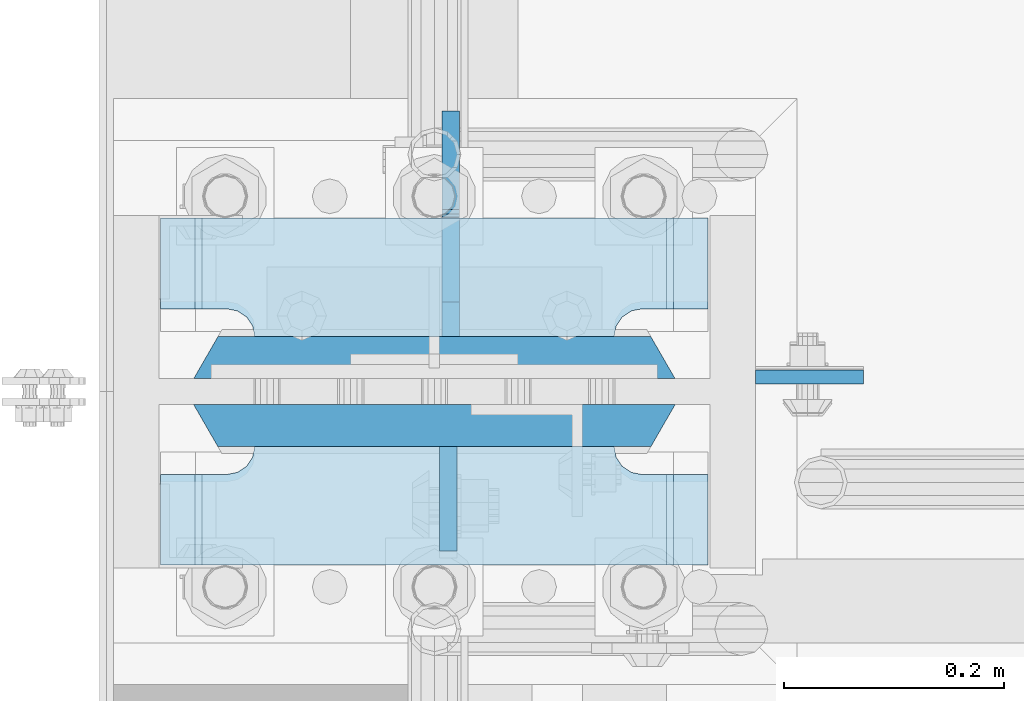
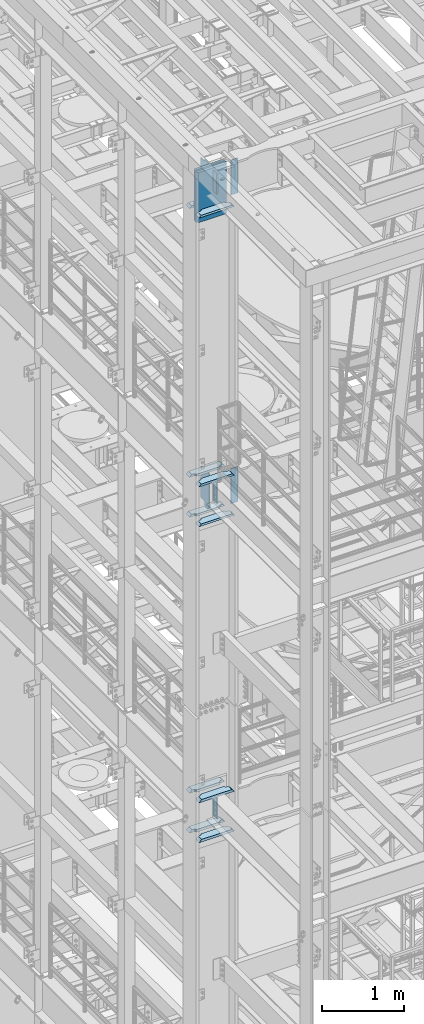
# One storey, part 1463 of 1876: 19 plates, 2 elements without a shape of their own.
"""IFC2X3 building model written with IfcOpenShell, lengths in millimetres."""

from ifc_helpers import new_model, si_unit, frame, origin_with_axes, place, context, subcontext, project, spatial, faceted_brep, material, type_object, element, aggregate, save


model = new_model("IFC2X3")

# Units and contexts
model_context = context("Model", 3, precision=1e-05, world=origin_with_axes())
body_context = subcontext(model_context, "Body", "Model", "MODEL_VIEW")
ifc_project = project(units=[si_unit("LENGTHUNIT", "METRE", prefix="MILLI"), si_unit("AREAUNIT", "SQUARE_METRE"), si_unit("VOLUMEUNIT", "CUBIC_METRE"), si_unit("MASSUNIT", "GRAM", prefix="KILO"), si_unit("TIMEUNIT", "SECOND"), si_unit("PLANEANGLEUNIT", "RADIAN"), si_unit("SOLIDANGLEUNIT", "STERADIAN"), si_unit("THERMODYNAMICTEMPERATUREUNIT", "DEGREE_CELSIUS"), si_unit("LUMINOUSINTENSITYUNIT", "LUMEN")], contexts=[model_context])

# Site, building, storey
site_placement = place(None, origin_with_axes())
site = spatial("IfcSite", under=ifc_project, at=site_placement, CompositionType="ELEMENT")
building_placement = place(site_placement, origin_with_axes())
building = spatial("IfcBuilding", under=site, at=building_placement, Name="Undefined", CompositionType="ELEMENT")
storey_placement = place(building_placement, origin_with_axes())
storey = spatial("IfcBuildingStorey", under=building, at=storey_placement, Name="Undefined", CompositionType="ELEMENT", Elevation=0.0)

# Assembly, plates
assembly_1_placement = place(storey_placement, origin_with_axes())
assembly_1 = element("IfcElementAssembly", 1, at=assembly_1_placement, inside=storey, Name="COLUMN", AssemblyPlace="NOTDEFINED", PredefinedType="RIGID_FRAME")
ifc_material_1 = material(Name="STEEL/A572-50")
plate_type_1 = type_object("IfcPlateType", PredefinedType="NOTDEFINED")
plate_1_placement = place(assembly_1_placement, frame((292.1, -4558.50699987411, 17929.225), z_axis=(1.0, 0.0, 0.0), x_axis=(0.0, 0.0, -1.0)))
plate_1 = element("IfcPlate", 2, at=plate_1_placement, type_object=plate_type_1, material=ifc_material_1, Name="PLATE", context=body_context, shape_type="Brep", body=[
    faceted_brep([(0.0, -6.35000000000036, 0.0), (0.0, -6.34999999999991, 98.4250030517578), (0.0, 6.34999999999991, 98.4250030517578), (0.0, 6.35000000000036, 0.0), (514.349975585938, -6.35000000000036, 98.4250030517578), (514.349975585938, 6.35000000000036, 98.4250030517578), (514.349975585938, -6.35000000000036, 0.0), (514.349975585938, 6.35000000000036, 0.0)], [[[0, 1, 2, 3]], [[1, 4, 5, 2]], [[4, 6, 7, 5]], [[6, 0, 3, 7]], [[5, 7, 3, 2]], [[6, 4, 1, 0]]]),
])
plate_2_placement = place(assembly_1_placement, frame((292.1, -4558.50699987411, 22501.225), z_axis=(1.0, 0.0, 0.0), x_axis=(0.0, 0.0, -1.0)))
plate_2 = element("IfcPlate", 3, at=plate_2_placement, type_object=plate_type_1, material=ifc_material_1, Name="PLATE", context=body_context, shape_type="Brep", body=[
    faceted_brep([(0.0, -6.35000000000036, 0.0), (0.0, -6.34999999999991, 98.4250030517578), (0.0, 6.34999999999991, 98.4250030517578), (0.0, 6.35000000000036, 0.0), (514.349975585938, -6.35000000000036, 98.4250030517578), (514.349975585938, 6.35000000000036, 98.4250030517578), (514.349975585938, -6.35000000000036, 0.0), (514.349975585938, 6.35000000000036, 0.0)], [[[0, 1, 2, 3]], [[1, 4, 5, 2]], [[4, 6, 7, 5]], [[6, 0, 3, 7]], [[5, 7, 3, 2]], [[6, 4, 1, 0]]]),
])
ifc_material_2 = material(Name="STEEL/A572-GR.50")
plate_type_2 = type_object("IfcPlateType", PredefinedType="NOTDEFINED")
plate_3_placement = place(assembly_1_placement, frame((-219.075, -4541.04375, 22523.45), z_axis=(1.0, 0.0, 0.0), x_axis=(0.0, 0.0, -1.0)))
plate_3 = element("IfcPlate", 4, at=plate_3_placement, type_object=plate_type_2, material=ifc_material_2, Name="PLATE", context=body_context, shape_type="Brep", body=[
    faceted_brep([(0.0, 19.0500000000002, 416.152954742277), (0.0, -19.0500000000002, 438.149993896484), (742.950012207031, -19.0500000000002, 438.149993896484), (742.950012207031, 19.0500000000002, 416.152954742277), (742.950012207031, 19.0500000000002, 21.9970452577325), (0.0, 19.0500000000002, 21.9970452577367), (0.0, -19.0500000000002, 0.0), (742.950012207031, -19.0500000000002, 0.0)], [[[0, 1, 2, 3]], [[0, 3, 4, 5]], [[1, 0, 5, 6]], [[2, 1, 6, 7]], [[3, 2, 7, 4]], [[6, 5, 4, 7]]]),
])
plate_4_placement = place(assembly_1_placement, frame((-219.075, -4602.95625, 22523.45), z_axis=(1.0, 0.0, 0.0), x_axis=(0.0, 0.0, -1.0)))
plate_4 = element("IfcPlate", 5, at=plate_4_placement, type_object=plate_type_2, material=ifc_material_2, Name="PLATE", context=body_context, shape_type="Brep", body=[
    faceted_brep([(0.0, -19.0500000000002, 416.152954749452), (742.950012207031, -19.0500000000002, 416.152954749372), (742.950012207031, 19.0500000000002, 438.149993896484), (0.0, 19.0500000000002, 438.149993896484), (742.950012207031, -19.0500000000002, 21.9970452506512), (742.950012207031, 19.0500000000002, 0.0), (-9.09494701772928e-13, 19.05, -1.81898940354586e-12), (0.0, -19.0500000000002, 21.9970452506512)], [[[0, 1, 2, 3]], [[2, 1, 4, 5]], [[3, 2, 5, 6]], [[0, 3, 6, 7]], [[1, 0, 7, 4]], [[6, 5, 4, 7]]]),
])
plate_type_3 = type_object("IfcPlateType", PredefinedType="NOTDEFINED")
plate_5_placement = place(assembly_1_placement, frame((12.6995000839233, -4622.00625, 22491.7), z_axis=(0.0, -1.0, 0.0), x_axis=(0.0, 0.0, -1.0)))
plate_5 = element("IfcPlate", 6, at=plate_5_placement, type_object=plate_type_3, material=ifc_material_1, Name="PLATE", context=body_context, shape_type="Brep", body=[
    faceted_brep([(0.0, -7.9375, 0.0), (0.0, -7.9375, 95.25), (0.0, 7.9375, 95.25), (0.0, 7.9375, 0.0), (304.799987792969, -7.9375, 95.25), (304.799987792969, 7.9375, 95.25), (304.799987792969, -7.9375, 0.0), (304.799987792969, 7.9375, 0.0)], [[[0, 1, 2, 3]], [[1, 4, 5, 2]], [[4, 6, 7, 5]], [[6, 0, 3, 7]], [[5, 7, 3, 2]], [[6, 4, 1, 0]]]),
])
plate_6_placement = place(assembly_1_placement, frame((12.6995000839233, -4622.00625, 17919.7), z_axis=(0.0, -1.0, 0.0), x_axis=(0.0, 0.0, -1.0)))
plate_6 = element("IfcPlate", 7, at=plate_6_placement, type_object=plate_type_3, material=ifc_material_1, Name="PLATE", context=body_context, shape_type="Brep", body=[
    faceted_brep([(0.0, -7.9375, 0.0), (0.0, -7.9375, 95.25), (0.0, 7.9375, 95.25), (0.0, 7.9375, 0.0), (304.799987792969, -7.9375, 95.25), (304.799987792969, 7.9375, 95.25), (304.799987792969, -7.9375, 0.0), (304.799987792969, 7.9375, 0.0)], [[[0, 1, 2, 3]], [[1, 4, 5, 2]], [[4, 6, 7, 5]], [[6, 0, 3, 7]], [[5, 7, 3, 2]], [[6, 4, 1, 0]]]),
])

# Assembly, plate
assembly_2_placement = place(storey_placement, origin_with_axes())
assembly_2 = element("IfcElementAssembly", 8, at=assembly_2_placement, inside=storey, Name="COLUMN", AssemblyPlace="NOTDEFINED", PredefinedType="RIGID_FRAME")
ifc_material_3 = material(Name="STEEL/A36")
plate_7_placement = place(assembly_2_placement, frame((12.6995000839233, -4622.00625, 13246.1), z_axis=(0.0, -1.0, 0.0), x_axis=(0.0, 0.0, -1.0)))
plate_7 = element("IfcPlate", 9, at=plate_7_placement, type_object=plate_type_3, material=ifc_material_3, Name="PLATE", context=body_context, shape_type="Brep", body=[
    faceted_brep([(0.0, -7.9375, 0.0), (0.0, -7.9375, 95.25), (0.0, 7.9375, 95.25), (0.0, 7.9375, 0.0), (304.799987792969, -7.9375, 95.25), (304.799987792969, 7.9375, 95.25), (304.799987792969, -7.9375, 0.0), (304.799987792969, 7.9375, 0.0)], [[[0, 1, 2, 3]], [[1, 4, 5, 2]], [[4, 6, 7, 5]], [[6, 0, 3, 7]], [[5, 7, 3, 2]], [[6, 4, 1, 0]]]),
])

# Plate
plate_type_4 = type_object("IfcPlateType", PredefinedType="NOTDEFINED")
plate_8_placement = place(assembly_1_placement, frame((249.2375, -4622.00625, 17376.775012207), z_axis=(-1.0, 0.0, 0.0), x_axis=(0.0, -1.0, 0.0)))
plate_8 = element("IfcPlate", 10, at=plate_8_placement, type_object=plate_type_4, material=ifc_material_1, Name="PLATE", context=body_context, shape_type="Brep", body=[
    faceted_brep([(107.949996948242, -15.875, 498.475006103516), (107.949996948242, 15.875, 467.025007631571), (25.3999996185303, 15.875, 467.025007631571), (25.3999996185303, -15.875, 498.475006103516), (23.4665397733534, -15.875, 428.429848211837), (25.3999996185303, -15.875, 438.150007247925), (25.3999996185303, 15.875, 438.150007247925), (23.4665397733534, 15.875, 428.429848211837), (17.9605119723965, -15.875, 420.189495275529), (17.9605119723965, 15.875, 420.189495275529), (9.72015903608917, -15.875, 414.683467474573), (9.72015903608917, 15.875, 414.683467474573), (0.0, -15.875, 412.750007629395), (0.0, 15.875, 412.750007629395), (0.0, -15.875, 85.7249984741211), (0.0, 15.875, 85.7249984741211), (9.72015903609099, -15.875, 83.7915386289454), (9.72015903609099, 15.875, 83.7915386289454), (17.9605119723983, -15.875, 78.2855108279892), (17.9605119723983, 15.875, 78.2855108279892), (23.4665397733552, -15.875, 70.0451578916817), (23.4665397733552, 15.875, 70.0451578916817), (25.3999996185303, -15.875, 60.3249988555908), (25.3999996185303, 15.875, 60.3249988555908), (25.3999996185303, 15.875, 31.449998471945), (25.3999996185303, -15.875, 0.0), (107.949996948242, 15.875, 31.449998471945), (107.949996948242, -15.875, 0.0)], [[[0, 1, 2, 3]], [[4, 5, 6, 7]], [[8, 4, 7, 9]], [[10, 8, 9, 11]], [[12, 10, 11, 13]], [[14, 12, 13, 15]], [[16, 14, 15, 17]], [[18, 16, 17, 19]], [[20, 18, 19, 21]], [[22, 20, 21, 23]], [[22, 23, 24, 25]], [[26, 27, 25, 24]], [[5, 4, 8, 10, 12, 14, 16, 18, 20, 22, 25, 27, 0, 3]], [[6, 5, 3, 2]], [[26, 24, 23, 21, 19, 17, 15, 13, 11, 9, 7, 6, 2, 1]], [[27, 26, 1, 0]]]),
])

plate_9_placement = place(assembly_1_placement, frame((249.2375, -4622.00625, 17967.325), z_axis=(-1.0, 0.0, 0.0), x_axis=(0.0, -1.0, 0.0)))
plate_9 = element("IfcPlate", 11, at=plate_9_placement, type_object=plate_type_4, material=ifc_material_1, Name="PLATE", context=body_context, shape_type="Brep", body=[
    faceted_brep([(107.949996948242, -15.875, 498.475006103516), (107.949996948242, 15.875, 467.025007631571), (25.3999996185303, 15.875, 467.025007631571), (25.3999996185303, -15.875, 498.475006103516), (23.4665397733534, -15.875, 428.429848211837), (25.3999996185303, -15.875, 438.150007247925), (25.3999996185303, 15.875, 438.150007247925), (23.4665397733534, 15.875, 428.429848211837), (17.9605119723965, -15.875, 420.189495275529), (17.9605119723965, 15.875, 420.189495275529), (9.72015903608917, -15.875, 414.683467474573), (9.72015903608917, 15.875, 414.683467474573), (0.0, -15.875, 412.750007629395), (0.0, 15.875, 412.750007629395), (0.0, -15.875, 85.7249984741211), (0.0, 15.875, 85.7249984741211), (9.72015903609099, -15.875, 83.7915386289454), (9.72015903609099, 15.875, 83.7915386289454), (17.9605119723983, -15.875, 78.2855108279892), (17.9605119723983, 15.875, 78.2855108279892), (23.4665397733552, -15.875, 70.0451578916817), (23.4665397733552, 15.875, 70.0451578916817), (25.3999996185303, -15.875, 60.3249988555908), (25.3999996185303, 15.875, 60.3249988555908), (25.3999996185303, 15.875, 31.449998471945), (25.3999996185303, -15.875, 0.0), (107.949996948242, 15.875, 31.449998471945), (107.949996948242, -15.875, 0.0)], [[[0, 1, 2, 3]], [[4, 5, 6, 7]], [[8, 4, 7, 9]], [[10, 8, 9, 11]], [[12, 10, 11, 13]], [[14, 12, 13, 15]], [[16, 14, 15, 17]], [[18, 16, 17, 19]], [[20, 18, 19, 21]], [[22, 20, 21, 23]], [[22, 23, 24, 25]], [[26, 27, 25, 24]], [[5, 4, 8, 10, 12, 14, 16, 18, 20, 22, 25, 27, 0, 3]], [[6, 5, 3, 2]], [[26, 24, 23, 21, 19, 17, 15, 13, 11, 9, 7, 6, 2, 1]], [[27, 26, 1, 0]]]),
])

plate_10_placement = place(assembly_1_placement, frame((249.2375, -4414.04375, 17376.775012207), z_axis=(-1.0, 0.0, 0.0), x_axis=(0.0, -1.0, 0.0)))
plate_10 = element("IfcPlate", 12, at=plate_10_placement, type_object=plate_type_4, material=ifc_material_1, Name="PLATE", context=body_context, shape_type="Brep", body=[
    faceted_brep([(82.5499973297119, -15.875, 498.475006103516), (82.5499973297119, 15.875, 467.025007631571), (0.0, 15.875, 467.025007631571), (0.0, -15.875, 498.475006103516), (82.5499973297119, 15.875, 31.449998471945), (82.5499973297119, -15.875, 0.0), (0.0, -15.875, 0.0), (0.0, 15.875, 31.449998471945), (82.5499973297119, 15.875, 60.3249988555908), (82.5499973297119, -15.875, 60.3249988555908), (84.4834571748879, -15.875, 70.045157891682), (84.4834571748879, 15.875, 70.045157891682), (89.9894849758439, -15.875, 78.2855108279893), (89.9894849758439, 15.875, 78.2855108279893), (98.2298379121512, -15.875, 83.7915386289454), (98.2298379121512, 15.875, 83.7915386289454), (107.949996948242, -15.875, 85.7249984741211), (107.949996948242, 15.875, 85.7249984741211), (107.949996948242, -15.875, 412.750007629395), (107.949996948242, 15.875, 412.750007629395), (98.2298379121512, -15.875, 414.68346747457), (98.2298379121512, 15.875, 414.68346747457), (89.989484975843, -15.875, 420.189495275526), (89.989484975843, 15.875, 420.189495275526), (84.483457174887, -15.875, 428.429848211834), (84.483457174887, 15.875, 428.429848211834), (82.5499973297119, -15.875, 438.150007247925), (82.5499973297119, 15.875, 438.150007247925)], [[[0, 1, 2, 3]], [[4, 5, 6, 7]], [[8, 9, 5, 4]], [[10, 9, 8, 11]], [[12, 10, 11, 13]], [[14, 12, 13, 15]], [[16, 14, 15, 17]], [[18, 16, 17, 19]], [[20, 18, 19, 21]], [[22, 20, 21, 23]], [[24, 22, 23, 25]], [[26, 24, 25, 27]], [[6, 5, 9, 10, 12, 14, 16, 18, 20, 22, 24, 26, 0, 3]], [[7, 6, 3, 2]], [[27, 25, 23, 21, 19, 17, 15, 13, 11, 8, 4, 7, 2, 1]], [[26, 27, 1, 0]]]),
])

plate_11_placement = place(assembly_1_placement, frame((249.2375, -4414.04375, 17967.325), z_axis=(-1.0, 0.0, 0.0), x_axis=(0.0, -1.0, 0.0)))
plate_11 = element("IfcPlate", 13, at=plate_11_placement, type_object=plate_type_4, material=ifc_material_1, Name="PLATE", context=body_context, shape_type="Brep", body=[
    faceted_brep([(82.5499973297119, -15.875, 498.475006103516), (82.5499973297119, 15.875, 467.025007631571), (0.0, 15.875, 467.025007631571), (0.0, -15.875, 498.475006103516), (82.5499973297119, 15.875, 31.449998471945), (82.5499973297119, -15.875, 0.0), (0.0, -15.875, 0.0), (0.0, 15.875, 31.449998471945), (82.5499973297119, 15.875, 60.3249988555908), (82.5499973297119, -15.875, 60.3249988555908), (84.4834571748879, -15.875, 70.045157891682), (84.4834571748879, 15.875, 70.045157891682), (89.9894849758439, -15.875, 78.2855108279893), (89.9894849758439, 15.875, 78.2855108279893), (98.2298379121512, -15.875, 83.7915386289454), (98.2298379121512, 15.875, 83.7915386289454), (107.949996948242, -15.875, 85.7249984741211), (107.949996948242, 15.875, 85.7249984741211), (107.949996948242, -15.875, 412.750007629395), (107.949996948242, 15.875, 412.750007629395), (98.2298379121512, -15.875, 414.68346747457), (98.2298379121512, 15.875, 414.68346747457), (89.989484975843, -15.875, 420.189495275526), (89.989484975843, 15.875, 420.189495275526), (84.483457174887, -15.875, 428.429848211834), (84.483457174887, 15.875, 428.429848211834), (82.5499973297119, -15.875, 438.150007247925), (82.5499973297119, 15.875, 438.150007247925)], [[[0, 1, 2, 3]], [[4, 5, 6, 7]], [[8, 9, 5, 4]], [[10, 9, 8, 11]], [[12, 10, 11, 13]], [[14, 12, 13, 15]], [[16, 14, 15, 17]], [[18, 16, 17, 19]], [[20, 18, 19, 21]], [[22, 20, 21, 23]], [[24, 22, 23, 25]], [[26, 24, 25, 27]], [[6, 5, 9, 10, 12, 14, 16, 18, 20, 22, 24, 26, 0, 3]], [[7, 6, 3, 2]], [[27, 25, 23, 21, 19, 17, 15, 13, 11, 8, 4, 7, 2, 1]], [[26, 27, 1, 0]]]),
])

plate_12_placement = place(assembly_1_placement, frame((249.2375, -4622.00625, 21948.775012207), z_axis=(-1.0, 0.0, 0.0), x_axis=(0.0, -1.0, 0.0)))
plate_12 = element("IfcPlate", 14, at=plate_12_placement, type_object=plate_type_4, material=ifc_material_1, Name="PLATE", context=body_context, shape_type="Brep", body=[
    faceted_brep([(107.949996948242, -15.875, 498.475006103516), (107.949996948242, 15.875, 467.025007631571), (25.3999996185303, 15.875, 467.025007631571), (25.3999996185303, -15.875, 498.475006103516), (23.4665397733534, -15.875, 428.429848211837), (25.3999996185303, -15.875, 438.150007247925), (25.3999996185303, 15.875, 438.150007247925), (23.4665397733534, 15.875, 428.429848211837), (17.9605119723965, -15.875, 420.189495275529), (17.9605119723965, 15.875, 420.189495275529), (9.72015903608917, -15.875, 414.683467474573), (9.72015903608917, 15.875, 414.683467474573), (0.0, -15.875, 412.750007629395), (0.0, 15.875, 412.750007629395), (0.0, -15.875, 85.7249984741211), (0.0, 15.875, 85.7249984741211), (9.72015903609099, -15.875, 83.7915386289454), (9.72015903609099, 15.875, 83.7915386289454), (17.9605119723983, -15.875, 78.2855108279892), (17.9605119723983, 15.875, 78.2855108279892), (23.4665397733552, -15.875, 70.0451578916817), (23.4665397733552, 15.875, 70.0451578916817), (25.3999996185303, -15.875, 60.3249988555908), (25.3999996185303, 15.875, 60.3249988555908), (25.3999996185303, 15.875, 31.449998471945), (25.3999996185303, -15.875, 0.0), (107.949996948242, 15.875, 31.449998471945), (107.949996948242, -15.875, 0.0)], [[[0, 1, 2, 3]], [[4, 5, 6, 7]], [[8, 4, 7, 9]], [[10, 8, 9, 11]], [[12, 10, 11, 13]], [[14, 12, 13, 15]], [[16, 14, 15, 17]], [[18, 16, 17, 19]], [[20, 18, 19, 21]], [[22, 20, 21, 23]], [[22, 23, 24, 25]], [[26, 27, 25, 24]], [[5, 4, 8, 10, 12, 14, 16, 18, 20, 22, 25, 27, 0, 3]], [[6, 5, 3, 2]], [[26, 24, 23, 21, 19, 17, 15, 13, 11, 9, 7, 6, 2, 1]], [[27, 26, 1, 0]]]),
])

plate_13_placement = place(assembly_1_placement, frame((249.2375, -4414.04375, 21948.775012207), z_axis=(-1.0, 0.0, 0.0), x_axis=(0.0, -1.0, 0.0)))
plate_13 = element("IfcPlate", 15, at=plate_13_placement, type_object=plate_type_4, material=ifc_material_1, Name="PLATE", context=body_context, shape_type="Brep", body=[
    faceted_brep([(82.5499973297119, -15.875, 498.475006103516), (82.5499973297119, 15.875, 467.025007631571), (0.0, 15.875, 467.025007631571), (0.0, -15.875, 498.475006103516), (82.5499973297119, 15.875, 31.449998471945), (82.5499973297119, -15.875, 0.0), (0.0, -15.875, 0.0), (0.0, 15.875, 31.449998471945), (82.5499973297119, 15.875, 60.3249988555908), (82.5499973297119, -15.875, 60.3249988555908), (84.4834571748879, -15.875, 70.045157891682), (84.4834571748879, 15.875, 70.045157891682), (89.9894849758439, -15.875, 78.2855108279893), (89.9894849758439, 15.875, 78.2855108279893), (98.2298379121512, -15.875, 83.7915386289454), (98.2298379121512, 15.875, 83.7915386289454), (107.949996948242, -15.875, 85.7249984741211), (107.949996948242, 15.875, 85.7249984741211), (107.949996948242, -15.875, 412.750007629395), (107.949996948242, 15.875, 412.750007629395), (98.2298379121512, -15.875, 414.68346747457), (98.2298379121512, 15.875, 414.68346747457), (89.989484975843, -15.875, 420.189495275526), (89.989484975843, 15.875, 420.189495275526), (84.483457174887, -15.875, 428.429848211834), (84.483457174887, 15.875, 428.429848211834), (82.5499973297119, -15.875, 438.150007247925), (82.5499973297119, 15.875, 438.150007247925)], [[[0, 1, 2, 3]], [[4, 5, 6, 7]], [[8, 9, 5, 4]], [[10, 9, 8, 11]], [[12, 10, 11, 13]], [[14, 12, 13, 15]], [[16, 14, 15, 17]], [[18, 16, 17, 19]], [[20, 18, 19, 21]], [[22, 20, 21, 23]], [[24, 22, 23, 25]], [[26, 24, 25, 27]], [[6, 5, 9, 10, 12, 14, 16, 18, 20, 22, 24, 26, 0, 3]], [[7, 6, 3, 2]], [[27, 25, 23, 21, 19, 17, 15, 13, 11, 8, 4, 7, 2, 1]], [[26, 27, 1, 0]]]),
])

plate_type_5 = type_object("IfcPlateType", PredefinedType="NOTDEFINED")
plate_14_placement = place(assembly_1_placement, frame((15.0812499999994, -4521.99375, 17951.45), z_axis=(0.0, 1.0, 0.0), x_axis=(0.0, 0.0, -1.0)))
plate_14 = element("IfcPlate", 16, at=plate_14_placement, type_object=plate_type_5, material=ifc_material_3, Name="PLATE", context=body_context, shape_type="Brep", body=[
    faceted_brep([(488.949999999997, -7.93749999999998, 205.581253456207), (488.949999999997, -7.93749999999998, 120.649999809266), (488.949999999997, 7.93749999999999, 120.649999809266), (488.949999999997, 7.93749999999999, 205.581253051758), (489.916729922585, -7.93749999999998, 115.78992029122), (489.916729922585, 7.93749999999999, 115.78992029122), (492.669743823062, -7.93749999999998, 111.669743823067), (492.669743823062, 7.93749999999999, 111.669743823067), (496.789920291216, -7.93749999999998, 108.916729922588), (496.789920291216, 7.93749999999999, 108.916729922588), (501.649999809262, -7.93749999999998, 107.950000000001), (501.649999809262, 7.93749999999999, 107.950000000001), (558.799987792969, -7.93749999999998, 107.950000000001), (558.799987792969, 7.93749999999999, 107.950000000001), (31.7499984741225, -7.93749999999998, 205.581256103516), (31.7499984741225, 7.93749999999999, 205.581253051758), (31.7499984741225, 7.93749999999999, 120.649999809266), (31.7499984741225, -7.93749999999998, 120.649999809266), (30.783268551535, 7.93749999999999, 115.78992029122), (30.783268551535, -7.93749999999998, 115.78992029122), (28.0302546510575, 7.93749999999999, 111.669743823067), (28.0302546510575, -7.93749999999998, 111.669743823067), (23.9100781829038, 7.93749999999999, 108.916729922588), (23.9100781829038, -7.93749999999998, 108.916729922588), (19.0499986648574, 7.93749999999999, 107.950000000001), (19.0499986648574, -7.93749999999998, 107.950000000001), (0.0, 7.93749999999999, 107.950000000001), (0.0, -7.93749999999998, 107.950000000001), (0.0, 7.93749999999999, 31.75), (0.0, -7.93749999999998, 31.75), (31.75, -7.93749999999998, 0.0), (31.75, 7.93749999999999, 0.0), (527.049987792969, -7.93749999999998, 0.0), (527.049987792969, 7.93749999999999, 0.0), (558.799987792969, -7.93749999999998, 31.75), (558.799987792969, 7.93749999999999, 31.75)], [[[0, 1, 2, 3]], [[4, 5, 2, 1]], [[6, 7, 5, 4]], [[8, 9, 7, 6]], [[10, 11, 9, 8]], [[12, 13, 11, 10]], [[14, 15, 16, 17]], [[17, 16, 18, 19]], [[19, 18, 20, 21]], [[21, 20, 22, 23]], [[23, 22, 24, 25]], [[25, 24, 26, 27]], [[28, 29, 27, 26]], [[30, 29, 28, 31]], [[32, 30, 31, 33]], [[34, 32, 33, 35]], [[8, 6, 4, 1, 0, 14, 17, 19, 21, 23, 25, 27, 29, 30, 32, 34, 12, 10]], [[15, 14, 0, 3]], [[35, 33, 31, 28, 26, 24, 22, 20, 18, 16, 15, 3, 2, 5, 7, 9, 11, 13]], [[34, 35, 13, 12]]]),
])

plate_15_placement = place(assembly_1_placement, frame((15.080500125885, -4521.99375, 22523.45), z_axis=(0.0, 1.0, 0.0), x_axis=(0.0, 0.0, -1.0)))
plate_15 = element("IfcPlate", 17, at=plate_15_placement, type_object=plate_type_5, material=ifc_material_3, Name="PLATE", context=body_context, shape_type="Brep", body=[
    faceted_brep([(488.949999999997, -7.93749999999998, 205.581253456207), (488.949999999997, -7.93749999999998, 120.649999809266), (488.949999999997, 7.93749999999999, 120.649999809266), (488.949999999997, 7.93749999999999, 205.581253051758), (489.916729922585, -7.93749999999998, 115.78992029122), (489.916729922585, 7.93749999999999, 115.78992029122), (492.669743823062, -7.93749999999998, 111.669743823067), (492.669743823062, 7.93749999999999, 111.669743823067), (496.789920291216, -7.93749999999998, 108.916729922588), (496.789920291216, 7.93749999999999, 108.916729922588), (501.649999809262, -7.93749999999998, 107.950000000001), (501.649999809262, 7.93749999999999, 107.950000000001), (558.799987792969, -7.93749999999998, 107.950000000001), (558.799987792969, 7.93749999999999, 107.950000000001), (31.7499984741225, -7.93749999999998, 205.581256103516), (31.7499984741225, 7.93749999999999, 205.581253051758), (31.7499984741225, 7.93749999999999, 120.649999809266), (31.7499984741225, -7.93749999999998, 120.649999809266), (30.783268551535, 7.93749999999999, 115.78992029122), (30.783268551535, -7.93749999999998, 115.78992029122), (28.0302546510575, 7.93749999999999, 111.669743823067), (28.0302546510575, -7.93749999999998, 111.669743823067), (23.9100781829038, 7.93749999999999, 108.916729922588), (23.9100781829038, -7.93749999999998, 108.916729922588), (19.0499986648574, 7.93749999999999, 107.950000000001), (19.0499986648574, -7.93749999999998, 107.950000000001), (0.0, 7.93749999999999, 107.950000000001), (0.0, -7.93749999999998, 107.950000000001), (0.0, 7.93749999999999, 31.75), (0.0, -7.93749999999998, 31.75), (31.75, -7.93749999999998, 0.0), (31.75, 7.93749999999999, 0.0), (527.049987792969, -7.93749999999998, 0.0), (527.049987792969, 7.93749999999999, 0.0), (558.799987792969, -7.93749999999998, 31.75), (558.799987792969, 7.93749999999999, 31.75)], [[[0, 1, 2, 3]], [[4, 5, 2, 1]], [[6, 7, 5, 4]], [[8, 9, 7, 6]], [[10, 11, 9, 8]], [[12, 13, 11, 10]], [[14, 15, 16, 17]], [[17, 16, 18, 19]], [[19, 18, 20, 21]], [[21, 20, 22, 23]], [[23, 22, 24, 25]], [[25, 24, 26, 27]], [[28, 29, 27, 26]], [[30, 29, 28, 31]], [[32, 30, 31, 33]], [[34, 32, 33, 35]], [[8, 6, 4, 1, 0, 14, 17, 19, 21, 23, 25, 27, 29, 30, 32, 34, 12, 10]], [[15, 14, 0, 3]], [[35, 33, 31, 28, 26, 24, 22, 20, 18, 16, 15, 3, 2, 5, 7, 9, 11, 13]], [[34, 35, 13, 12]]]),
])

aggregate(assembly_1, [plate_5, plate_6, plate_8, plate_9, plate_10, plate_11, plate_14, plate_1, plate_2, plate_12, plate_13, plate_15, plate_3, plate_4])

plate_type_6 = type_object("IfcPlateType", PredefinedType="NOTDEFINED")
plate_16_placement = place(assembly_2_placement, frame((249.2375, -4622.00625, 12699.999987793), z_axis=(-1.0, 0.0, 0.0), x_axis=(0.0, -1.0, 0.0)))
plate_16 = element("IfcPlate", 18, at=plate_16_placement, type_object=plate_type_6, material=ifc_material_1, Name="PLATE", context=body_context, shape_type="Brep", body=[
    faceted_brep([(107.949996948242, -19.0499999999993, 498.475006103516), (107.949996948242, 19.0499999999993, 460.675005342751), (25.3999996185303, 19.0499999999993, 460.675005342751), (25.3999996185303, -19.0499999999993, 498.475006103516), (23.4665397733534, -19.0499999999993, 428.429848211837), (25.3999996185303, -19.0499999999993, 438.150007247925), (25.3999996185303, 19.0499999999993, 438.150007247925), (23.4665397733534, 19.0499999999993, 428.429848211837), (17.9605119723965, -19.0499999999993, 420.189495275529), (17.9605119723965, 19.0499999999993, 420.189495275529), (9.72015903608917, -19.0499999999993, 414.683467474573), (9.72015903608917, 19.0499999999993, 414.683467474573), (0.0, -19.0499999999993, 412.750007629395), (0.0, 19.0499999999993, 412.750007629395), (0.0, -19.0499999999993, 85.7249984741211), (0.0, 19.0499999999993, 85.7249984741211), (9.72015903609099, -19.0499999999993, 83.7915386289451), (9.72015903609099, 19.0499999999993, 83.7915386289451), (17.9605119723983, -19.0499999999993, 78.2855108279891), (17.9605119723983, 19.0499999999993, 78.2855108279891), (23.4665397733552, -19.0499999999993, 70.0451578916818), (23.4665397733552, 19.0499999999993, 70.0451578916818), (25.3999996185303, -19.0499999999993, 60.3249988555908), (25.3999996185303, 19.0499999999993, 60.3249988555908), (25.3999996185303, 19.0499999999993, 37.8000007607643), (25.3999996185303, -19.0499999999993, 0.0), (107.949996948242, 19.0499999999993, 37.8000007607643), (107.949996948242, -19.0499999999993, 0.0)], [[[0, 1, 2, 3]], [[4, 5, 6, 7]], [[8, 4, 7, 9]], [[10, 8, 9, 11]], [[12, 10, 11, 13]], [[14, 12, 13, 15]], [[16, 14, 15, 17]], [[18, 16, 17, 19]], [[20, 18, 19, 21]], [[22, 20, 21, 23]], [[22, 23, 24, 25]], [[26, 27, 25, 24]], [[5, 4, 8, 10, 12, 14, 16, 18, 20, 22, 25, 27, 0, 3]], [[6, 5, 3, 2]], [[26, 24, 23, 21, 19, 17, 15, 13, 11, 9, 7, 6, 2, 1]], [[27, 26, 1, 0]]]),
])

plate_17_placement = place(assembly_2_placement, frame((249.2375, -4622.00625, 13290.55), z_axis=(-1.0, 0.0, 0.0), x_axis=(0.0, -1.0, 0.0)))
plate_17 = element("IfcPlate", 19, at=plate_17_placement, type_object=plate_type_6, material=ifc_material_1, Name="PLATE", context=body_context, shape_type="Brep", body=[
    faceted_brep([(107.949996948242, -19.0499999999993, 498.475006103516), (107.949996948242, 19.0499999999993, 460.675005342751), (25.3999996185303, 19.0499999999993, 460.675005342751), (25.3999996185303, -19.0499999999993, 498.475006103516), (23.4665397733534, -19.0499999999993, 428.429848211837), (25.3999996185303, -19.0499999999993, 438.150007247925), (25.3999996185303, 19.0499999999993, 438.150007247925), (23.4665397733534, 19.0499999999993, 428.429848211837), (17.9605119723965, -19.0499999999993, 420.189495275529), (17.9605119723965, 19.0499999999993, 420.189495275529), (9.72015903608917, -19.0499999999993, 414.683467474573), (9.72015903608917, 19.0499999999993, 414.683467474573), (0.0, -19.0499999999993, 412.750007629395), (0.0, 19.0499999999993, 412.750007629395), (0.0, -19.0499999999993, 85.7249984741211), (0.0, 19.0499999999993, 85.7249984741211), (9.72015903609099, -19.0499999999993, 83.7915386289451), (9.72015903609099, 19.0499999999993, 83.7915386289451), (17.9605119723983, -19.0499999999993, 78.2855108279891), (17.9605119723983, 19.0499999999993, 78.2855108279891), (23.4665397733552, -19.0499999999993, 70.0451578916818), (23.4665397733552, 19.0499999999993, 70.0451578916818), (25.3999996185303, -19.0499999999993, 60.3249988555908), (25.3999996185303, 19.0499999999993, 60.3249988555908), (25.3999996185303, 19.0499999999993, 37.8000007607643), (25.3999996185303, -19.0499999999993, 0.0), (107.949996948242, 19.0499999999993, 37.8000007607643), (107.949996948242, -19.0499999999993, 0.0)], [[[0, 1, 2, 3]], [[4, 5, 6, 7]], [[8, 4, 7, 9]], [[10, 8, 9, 11]], [[12, 10, 11, 13]], [[14, 12, 13, 15]], [[16, 14, 15, 17]], [[18, 16, 17, 19]], [[20, 18, 19, 21]], [[22, 20, 21, 23]], [[22, 23, 24, 25]], [[26, 27, 25, 24]], [[5, 4, 8, 10, 12, 14, 16, 18, 20, 22, 25, 27, 0, 3]], [[6, 5, 3, 2]], [[26, 24, 23, 21, 19, 17, 15, 13, 11, 9, 7, 6, 2, 1]], [[27, 26, 1, 0]]]),
])

plate_18_placement = place(assembly_2_placement, frame((249.2375, -4414.04375, 12699.999987793), z_axis=(-1.0, 0.0, 0.0), x_axis=(0.0, -1.0, 0.0)))
plate_18 = element("IfcPlate", 20, at=plate_18_placement, type_object=plate_type_6, material=ifc_material_1, Name="PLATE", context=body_context, shape_type="Brep", body=[
    faceted_brep([(82.5499973297119, -19.0499999999993, 498.475006103516), (82.5499973297119, 19.0499999999993, 460.675005342751), (0.0, 19.0499999999993, 460.675005342751), (0.0, -19.0499999999993, 498.475006103516), (82.5499973297119, 19.0499999999993, 37.8000007607643), (82.5499973297119, -19.0499999999993, 0.0), (0.0, -19.0500000000002, 0.0), (0.0, 19.0499999999993, 37.8000007607643), (82.5499973297119, 19.0499999999993, 60.3249988555908), (82.5499973297119, -19.0499999999993, 60.3249988555908), (84.4834571748879, -19.0499999999993, 70.0451578916818), (84.4834571748879, 19.0499999999993, 70.0451578916818), (89.9894849758439, -19.0499999999993, 78.2855108279891), (89.9894849758439, 19.0499999999993, 78.2855108279891), (98.2298379121512, -19.0499999999993, 83.7915386289451), (98.2298379121512, 19.0499999999993, 83.7915386289451), (107.949996948242, -19.0499999999993, 85.7249984741211), (107.949996948242, 19.0499999999993, 85.7249984741211), (107.949996948242, -19.0499999999993, 412.750007629395), (107.949996948242, 19.0499999999993, 412.750007629395), (98.2298379121512, -19.0499999999993, 414.683467474571), (98.2298379121512, 19.0499999999993, 414.683467474571), (89.989484975843, -19.0499999999993, 420.189495275526), (89.989484975843, 19.0499999999993, 420.189495275526), (84.483457174887, -19.0499999999993, 428.429848211834), (84.483457174887, 19.0499999999993, 428.429848211834), (82.5499973297119, -19.0499999999993, 438.150007247925), (82.5499973297119, 19.0499999999993, 438.150007247925)], [[[0, 1, 2, 3]], [[4, 5, 6, 7]], [[8, 9, 5, 4]], [[10, 9, 8, 11]], [[12, 10, 11, 13]], [[14, 12, 13, 15]], [[16, 14, 15, 17]], [[18, 16, 17, 19]], [[20, 18, 19, 21]], [[22, 20, 21, 23]], [[24, 22, 23, 25]], [[26, 24, 25, 27]], [[6, 5, 9, 10, 12, 14, 16, 18, 20, 22, 24, 26, 0, 3]], [[7, 6, 3, 2]], [[27, 25, 23, 21, 19, 17, 15, 13, 11, 8, 4, 7, 2, 1]], [[26, 27, 1, 0]]]),
])

plate_19_placement = place(assembly_2_placement, frame((249.2375, -4414.04375, 13290.55), z_axis=(-1.0, 0.0, 0.0), x_axis=(0.0, -1.0, 0.0)))
plate_19 = element("IfcPlate", 21, at=plate_19_placement, type_object=plate_type_6, material=ifc_material_1, Name="PLATE", context=body_context, shape_type="Brep", body=[
    faceted_brep([(82.5499973297119, -19.0499999999993, 498.475006103516), (82.5499973297119, 19.0499999999993, 460.675005342751), (0.0, 19.0499999999993, 460.675005342751), (0.0, -19.0499999999993, 498.475006103516), (82.5499973297119, 19.0499999999993, 37.8000007607643), (82.5499973297119, -19.0499999999993, 0.0), (0.0, -19.0500000000002, 0.0), (0.0, 19.0499999999993, 37.8000007607643), (82.5499973297119, 19.0499999999993, 60.3249988555908), (82.5499973297119, -19.0499999999993, 60.3249988555908), (84.4834571748879, -19.0499999999993, 70.0451578916818), (84.4834571748879, 19.0499999999993, 70.0451578916818), (89.9894849758439, -19.0499999999993, 78.2855108279891), (89.9894849758439, 19.0499999999993, 78.2855108279891), (98.2298379121512, -19.0499999999993, 83.7915386289451), (98.2298379121512, 19.0499999999993, 83.7915386289451), (107.949996948242, -19.0499999999993, 85.7249984741211), (107.949996948242, 19.0499999999993, 85.7249984741211), (107.949996948242, -19.0499999999993, 412.750007629395), (107.949996948242, 19.0499999999993, 412.750007629395), (98.2298379121512, -19.0499999999993, 414.683467474571), (98.2298379121512, 19.0499999999993, 414.683467474571), (89.989484975843, -19.0499999999993, 420.189495275526), (89.989484975843, 19.0499999999993, 420.189495275526), (84.483457174887, -19.0499999999993, 428.429848211834), (84.483457174887, 19.0499999999993, 428.429848211834), (82.5499973297119, -19.0499999999993, 438.150007247925), (82.5499973297119, 19.0499999999993, 438.150007247925)], [[[0, 1, 2, 3]], [[4, 5, 6, 7]], [[8, 9, 5, 4]], [[10, 9, 8, 11]], [[12, 10, 11, 13]], [[14, 12, 13, 15]], [[16, 14, 15, 17]], [[18, 16, 17, 19]], [[20, 18, 19, 21]], [[22, 20, 21, 23]], [[24, 22, 23, 25]], [[26, 24, 25, 27]], [[6, 5, 9, 10, 12, 14, 16, 18, 20, 22, 24, 26, 0, 3]], [[7, 6, 3, 2]], [[27, 25, 23, 21, 19, 17, 15, 13, 11, 8, 4, 7, 2, 1]], [[26, 27, 1, 0]]]),
])

aggregate(assembly_2, [plate_7, plate_16, plate_17, plate_18, plate_19])

save(model, "model.ifc")
